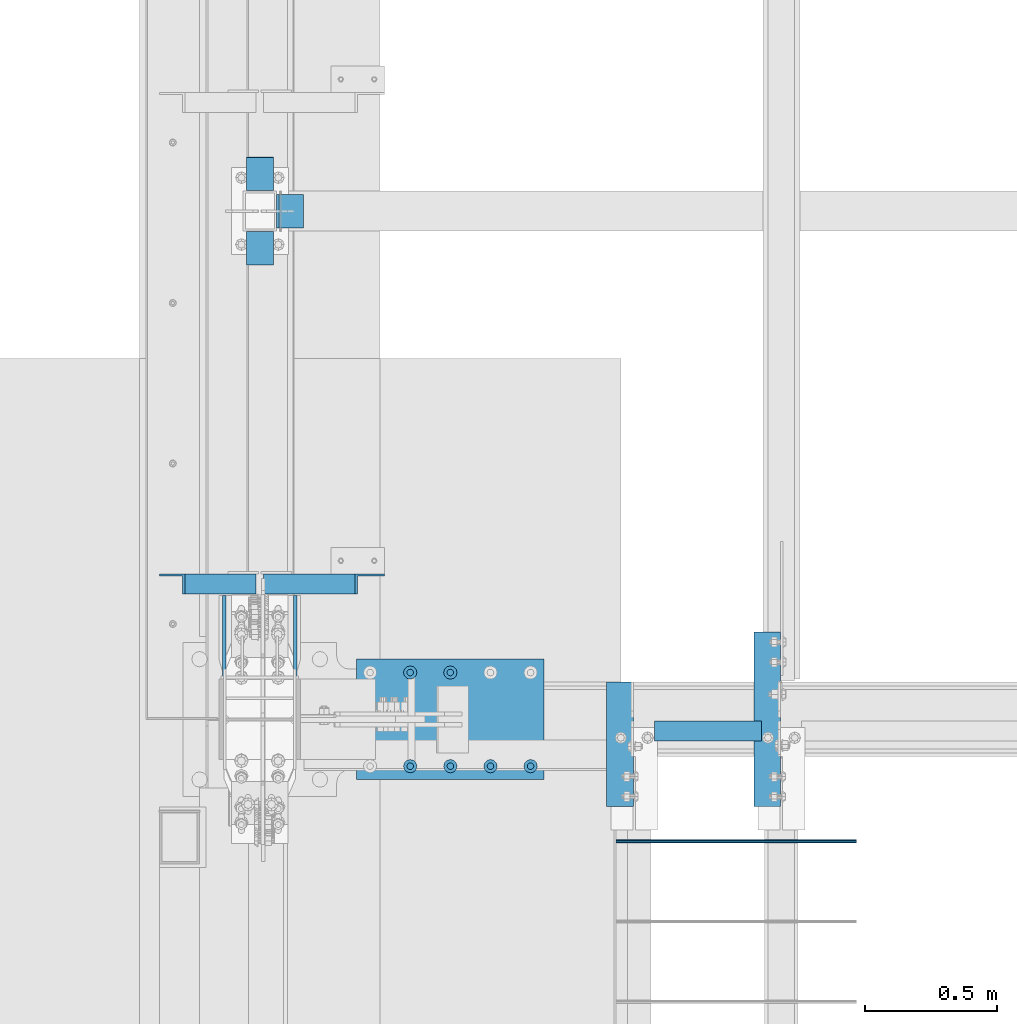
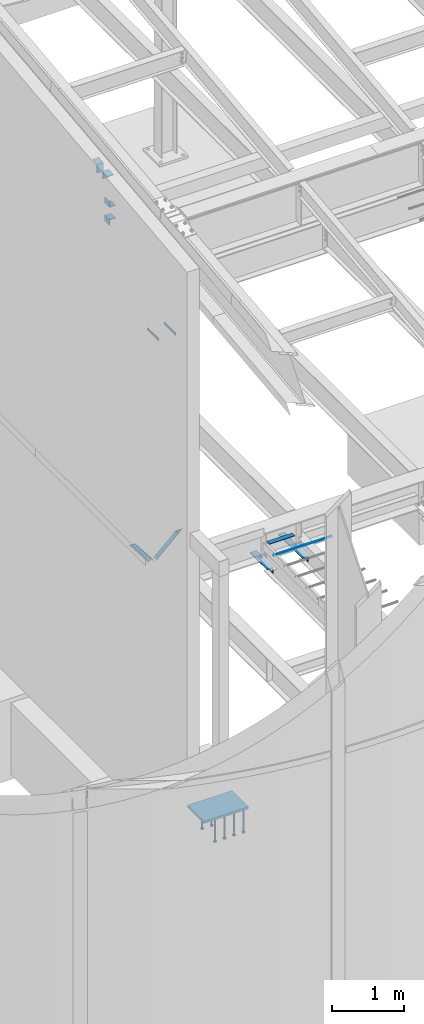
# One storey, part 806 of 1179: 17 beams, 2 members, 8 elements without a shape of their own.
"""IFC2X3 building model written with IfcOpenShell, lengths in millimetres."""

from ifc_helpers import new_model, si_unit, frame, origin_with_axes, place, context, subcontext, project, spatial, faceted_brep, material, type_object, element, aggregate, save


model = new_model("IFC2X3")

# Units and contexts
model_context = context("Model", 3, precision=1e-05, world=origin_with_axes())
body_context = subcontext(model_context, "Body", "Model", "MODEL_VIEW")
ifc_project = project(units=[si_unit("LENGTHUNIT", "METRE", prefix="MILLI"), si_unit("AREAUNIT", "SQUARE_METRE"), si_unit("VOLUMEUNIT", "CUBIC_METRE"), si_unit("MASSUNIT", "GRAM", prefix="KILO"), si_unit("TIMEUNIT", "SECOND"), si_unit("PLANEANGLEUNIT", "RADIAN"), si_unit("SOLIDANGLEUNIT", "STERADIAN"), si_unit("THERMODYNAMICTEMPERATUREUNIT", "DEGREE_CELSIUS"), si_unit("LUMINOUSINTENSITYUNIT", "LUMEN")], contexts=[model_context])

# Site, building, storey
site_placement = place(None, origin_with_axes())
site = spatial("IfcSite", under=ifc_project, at=site_placement, CompositionType="ELEMENT")
building_placement = place(site_placement, origin_with_axes())
building = spatial("IfcBuilding", under=site, at=building_placement, Name="Undefined", CompositionType="ELEMENT")
storey_placement = place(building_placement, origin_with_axes())
storey = spatial("IfcBuildingStorey", under=building, at=storey_placement, Name="Undefined", CompositionType="ELEMENT", Elevation=0.0)

# Assembly, beams
assembly_1_placement = place(storey_placement, origin_with_axes())
assembly_1 = element("IfcElementAssembly", 1, at=assembly_1_placement, inside=storey, Name="BEAM", AssemblyPlace="NOTDEFINED", PredefinedType="RIGID_FRAME")
ifc_material_1 = material(Name="STEEL/A36")
beam_type_1 = type_object("IfcBeamType", PredefinedType="NOTDEFINED")
beam_1_placement = place(assembly_1_placement, frame((432.347216092612, 7448.53595929762, 9390.66783296223), z_axis=(-1.0, 0.0, 0.0), x_axis=(0.0, 0.0, 1.0)))
beam_1 = element("IfcBeam", 2, at=beam_1_placement, type_object=beam_type_1, material=ifc_material_1, Name="BENT_PLATE", context=body_context, shape_type="Brep", body=[
    faceted_brep([(0.0, -4.76249999999982, -50.7999999999993), (0.0, -4.76249999999982, 50.7999999999993), (0.0, 4.76249999999982, 50.7999999999993), (0.0, 4.76249999999982, -50.7999999999993), (136.064419113565, 4.76249999999982, 50.8), (136.064419113565, 4.76249999999982, -50.8), (144.578182144351, -4.76249999999982, -50.8), (144.578182144351, -4.76249999999982, 50.8), (149.307267391649, 122.50635470422, 50.8), (149.307267391649, 122.50635470422, -50.8), (158.772587961741, 121.441774267915, 50.8), (158.772587961741, 121.441774267915, -50.8)], [[[0, 1, 2, 3]], [[3, 2, 4, 5]], [[1, 0, 6, 7]], [[5, 4, 8, 9]], [[4, 2, 1, 7, 10, 8]], [[7, 6, 11, 10]], [[6, 0, 3, 5, 9, 11]], [[10, 11, 9, 8]]]),
])
beam_2_placement = place(assembly_1_placement, frame((432.347216092612, 7162.55025962123, 9498.67298678495), z_axis=(1.0, 0.0, 0.0), x_axis=(0.0, 0.993674063495503, 0.11230251794299)))
beam_2 = element("IfcBeam", 3, at=beam_2_placement, type_object=beam_type_1, material=ifc_material_1, Name="BENT_PLATE", context=body_context, shape_type="Brep", body=[
    faceted_brep([(0.0, -4.76249999999982, -50.7999999999993), (0.0, -4.76249999999982, 50.7999999999993), (0.0, 4.76249999999982, 50.7999999999993), (0.0, 4.76249999999982, -50.7999999999993), (127.000478078538, 4.7624999806776, 50.8), (127.000478078538, 4.7624999806776, -50.8), (116.338348641526, -4.76250001769222, -50.8), (116.338348641526, -4.76250001769222, 50.8), (112.7380583003, -121.434106082392, 50.8), (112.7380583003, -121.434106082392, -50.8), (103.273312845498, -120.364424599007, 50.8), (103.273312845498, -120.364424599007, -50.8)], [[[0, 1, 2, 3]], [[3, 2, 4, 5]], [[1, 0, 6, 7]], [[5, 4, 8, 9]], [[4, 2, 1, 7, 10, 8]], [[7, 6, 11, 10]], [[6, 0, 3, 5, 9, 11]], [[10, 11, 9, 8]]]),
])
aggregate(assembly_1, [beam_1, beam_2])

# Assembly, member
assembly_2_placement = place(storey_placement, origin_with_axes())
assembly_2 = element("IfcElementAssembly", 4, at=assembly_2_placement, inside=storey, Name="ANGLE", AssemblyPlace="NOTDEFINED", PredefinedType="RIGID_FRAME")
member_type = type_object("IfcMemberType", Name="L3X3X1/4", PredefinedType="NOTDEFINED")
member_1_placement = place(assembly_2_placement, frame((472.414639168561, 5949.15999128227, 3736.19330123132), z_axis=(0.0, -1.0, 0.0), x_axis=(0.729484494811633, 0.0, 0.683997347823379)))
member_1 = element("IfcMember", 5, at=member_1_placement, type_object=member_type, material=ifc_material_1, Name="ANGLE", ObjectType="L3X3X1/4", context=body_context, shape_type="Brep", body=[
    faceted_brep([(0.0, 38.0999999999985, -38.0999999999999), (0.0, 38.0999999999985, 38.0999999999999), (475.752341075195, 38.0999999999181, 38.1000000000004), (475.752341075195, 38.0999999999181, -38.1000000000004), (0.0, 31.75, 38.1000000000004), (482.524628360803, 31.7499999999177, 38.1000000000004), (0.0, 31.75, -31.75), (482.524628360803, 31.7499999999177, -31.75), (0.0, -38.0999999999985, -31.75), (557.019788502486, -38.1000000000854, -31.75), (0.0, -38.0999999999985, -38.0999999999999), (557.019788502486, -38.1000000000854, -38.1000000000004)], [[[0, 1, 2, 3]], [[1, 4, 5, 2]], [[4, 6, 7, 5]], [[6, 8, 9, 7]], [[8, 10, 11, 9]], [[10, 0, 3, 11]], [[5, 7, 9, 11, 3, 2]], [[10, 8, 6, 4, 1, 0]]]),
])
aggregate(assembly_2, [member_1])

assembly_3_placement = place(storey_placement, origin_with_axes())
assembly_3 = element("IfcElementAssembly", 6, at=assembly_3_placement, inside=storey, Name="ANGLE", AssemblyPlace="NOTDEFINED", PredefinedType="RIGID_FRAME")
member_2_placement = place(assembly_3_placement, frame((80.8196258456446, 5949.15999128227, 4125.56128839178), z_axis=(0.0, -1.0, 0.0), x_axis=(0.614083067285056, 0.0, -0.789241399366364)))
member_2 = element("IfcMember", 7, at=member_2_placement, type_object=member_type, material=ifc_material_1, Name="ANGLE", ObjectType="L3X3X1/4", context=body_context, shape_type="Brep", body=[
    faceted_brep([(59.3707492954454, 38.0999999999781, -38.1000000000004), (59.3707492954454, 38.0999999999781, 38.1000000000004), (499.083854779058, 38.0999999998585, 38.1000000000004), (499.083854779058, 38.0999999998585, -38.1000000000004), (54.4300207928691, 31.7499999999804, 38.1000000000004), (499.083854779056, 31.7499999998595, 38.1000000000004), (54.4300207928691, 31.7499999999804, -31.75), (499.083854779056, 31.7499999998595, -31.75), (0.0820072645328764, -38.0999999999945, -31.75), (499.083854779043, -38.10000000013, -31.75), (0.0820072645328764, -38.0999999999945, -38.1000000000004), (499.083854779043, -38.10000000013, -38.1000000000004)], [[[0, 1, 2, 3]], [[1, 4, 5, 2]], [[4, 6, 7, 5]], [[6, 8, 9, 7]], [[8, 10, 11, 9]], [[10, 0, 3, 11]], [[5, 7, 9, 11, 3, 2]], [[10, 8, 6, 4, 1, 0]]]),
])
aggregate(assembly_3, [member_2])

# Assembly, beams
assembly_4_placement = place(storey_placement, origin_with_axes())
assembly_4 = element("IfcElementAssembly", 8, at=assembly_4_placement, inside=storey, Name="BEAM", AssemblyPlace="NOTDEFINED", PredefinedType="RIGID_FRAME")
beam_type_2 = type_object("IfcBeamType", Name="L4X4X1/2", PredefinedType="NOTDEFINED")
beam_3_placement = place(assembly_4_placement, frame((1800.22499984953, 5104.60611419343, 3584.575), z_axis=(0.0, 0.0, -1.0), x_axis=(0.0, 1.0, 0.0)))
beam_3 = element("IfcBeam", 9, at=beam_3_placement, type_object=beam_type_2, material=ifc_material_1, Name="ANGLE", ObjectType="L4X4X1/2", context=body_context, shape_type="Brep", body=[
    faceted_brep([(1.90993887372315e-11, 50.8000000000002, -50.8000000000002), (1.90993887372315e-11, 50.8000000000002, 50.8000000000002), (472.281387536708, 50.8000000000452, 50.8000000000002), (472.281387536708, 50.8000000000452, -50.8000000000002), (1.45519152283669e-11, 38.1000000000004, 50.8000000000002), (472.281387536704, 38.1000000000454, 50.8000000000002), (0.0, 38.0999999999985, -38.0999999999999), (472.281387536704, 38.1000000000454, -38.0999999999999), (-1.81898940354586e-11, -50.7999999999997, -38.0999999999999), (472.281387536672, -50.7999999999547, -38.0999999999999), (-1.81898940354586e-11, -50.7999999999997, -50.8000000000002), (472.281387536672, -50.7999999999547, -50.8000000000002)], [[[0, 1, 2, 3]], [[1, 4, 5, 2]], [[4, 6, 7, 5]], [[6, 8, 9, 7]], [[8, 10, 11, 9]], [[10, 0, 3, 11]], [[5, 7, 9, 11, 3, 2]], [[10, 8, 6, 4, 1, 0]]]),
])
beam_4_placement = place(assembly_4_placement, frame((2359.025, 5103.81250305176, 3584.575), z_axis=(0.0, 0.0, -1.0), x_axis=(0.0, 1.0, 0.0)))
beam_4 = element("IfcBeam", 10, at=beam_4_placement, type_object=beam_type_2, material=ifc_material_1, Name="ANGLE", ObjectType="L4X4X1/2", context=body_context, shape_type="Brep", body=[
    faceted_brep([(1.90993887372315e-11, 50.8000000000002, -50.8000000000002), (1.90993887372315e-11, 50.8000000000002, 50.8000000000002), (663.574996948242, 50.8000000000002, 50.8000000000002), (663.574996948242, 50.8000000000002, -50.8000000000002), (1.45519152283669e-11, 38.1000000000004, 50.8000000000002), (663.574996948242, 38.1000000000004, 50.8000000000002), (0.0, 38.0999999999985, -38.0999999999999), (663.574996948242, 38.1000000000004, -38.0999999999999), (-1.81898940354586e-11, -50.7999999999997, -38.0999999999999), (663.574996948242, -50.8000000000002, -38.0999999999999), (-1.81898940354586e-11, -50.7999999999997, -50.8000000000002), (663.574996948242, -50.8000000000002, -50.8000000000002)], [[[0, 1, 2, 3]], [[1, 4, 5, 2]], [[4, 6, 7, 5]], [[6, 8, 9, 7]], [[8, 10, 11, 9]], [[10, 0, 3, 11]], [[5, 7, 9, 11, 3, 2]], [[10, 8, 6, 4, 1, 0]]]),
])

assembly_5_placement = place(storey_placement, origin_with_axes())
assembly_5 = element("IfcElementAssembly", 11, at=assembly_5_placement, inside=storey, Name="COLUMN", AssemblyPlace="NOTDEFINED", PredefinedType="RIGID_FRAME")
beam_type_3 = type_object("IfcBeamType", Name="L4X4X3/8", PredefinedType="NOTDEFINED")
beam_5_placement = place(assembly_5_placement, frame((546.644791494267, 7302.5, 8597.9), z_axis=(1.0, 0.0, 0.0), x_axis=(0.0, 1.0, 0.0)))
beam_5 = element("IfcBeam", 12, at=beam_5_placement, type_object=beam_type_3, material=ifc_material_1, Name="ANGLE", ObjectType="L4X4X3/8", context=body_context, shape_type="Brep", body=[
    faceted_brep([(1.90993887372315e-11, 50.8000000000002, -50.8000000000002), (1.90993887372315e-11, 50.8000000000002, 50.8000000000002), (126.999999999993, 50.8000000000002, 50.7999999999993), (126.999999999993, 50.8000000000002, -50.7999999999993), (0.0, 41.2750000000015, 50.8000000000029), (126.999999999993, 41.2749999999996, 50.7999999999993), (0.0, 41.2750000000015, -41.2750000000015), (126.999999999993, 41.2749999999996, -41.2749999999996), (0.0, -50.7999999999993, -41.2750000000015), (126.999999999993, -50.8000000000002, -41.2749999999996), (-1.81898940354586e-11, -50.7999999999997, -50.8000000000002), (126.999999999993, -50.8000000000002, -50.7999999999993)], [[[0, 1, 2, 3]], [[1, 4, 5, 2]], [[4, 6, 7, 5]], [[6, 8, 9, 7]], [[8, 10, 11, 9]], [[10, 0, 3, 11]], [[5, 7, 9, 11, 3, 2]], [[10, 8, 6, 4, 1, 0]]]),
])
beam_6_placement = place(assembly_5_placement, frame((546.644791494267, 7302.5, 8904.2875), z_axis=(0.0, 0.0, 1.0), x_axis=(0.0, 1.0, 0.0)))
beam_6 = element("IfcBeam", 13, at=beam_6_placement, type_object=beam_type_3, material=ifc_material_1, Name="ANGLE", ObjectType="L4X4X3/8", context=body_context, shape_type="Brep", body=[
    faceted_brep([(1.90993887372315e-11, 50.8000000000002, -50.8000000000002), (1.90993887372315e-11, 50.8000000000002, 50.8000000000002), (126.999999999993, 50.8000000000002, 50.7999999999993), (126.999999999993, 50.8000000000002, -50.7999999999993), (0.0, 41.2750000000015, 50.8000000000029), (126.999999999993, 41.2749999999996, 50.7999999999993), (0.0, 41.2750000000015, -41.2750000000015), (126.999999999993, 41.2749999999996, -41.2749999999996), (0.0, -50.7999999999993, -41.2750000000015), (126.999999999993, -50.8000000000002, -41.2749999999996), (-1.81898940354586e-11, -50.7999999999997, -50.8000000000002), (126.999999999993, -50.8000000000002, -50.7999999999993)], [[[0, 1, 2, 3]], [[1, 4, 5, 2]], [[4, 6, 7, 5]], [[6, 8, 9, 7]], [[8, 10, 11, 9]], [[10, 0, 3, 11]], [[5, 7, 9, 11, 3, 2]], [[10, 8, 6, 4, 1, 0]]]),
])
aggregate(assembly_5, [beam_5, beam_6])

assembly_6_placement = place(storey_placement, origin_with_axes())
assembly_6 = element("IfcElementAssembly", 14, at=assembly_6_placement, inside=storey, Name="COLUMN", AssemblyPlace="NOTDEFINED", PredefinedType="RIGID_FRAME")
beam_type_4 = type_object("IfcBeamType", PredefinedType="NOTDEFINED")
beam_7_placement = place(assembly_6_placement, frame((296.862500000007, 5905.49999998408, 7727.95000000912), z_axis=(0.0, 0.0, 1.0), x_axis=(0.0, -1.0, 0.0)))
beam_7 = element("IfcBeam", 15, at=beam_7_placement, type_object=beam_type_4, material=ifc_material_1, Name="PLATE", context=body_context, shape_type="Brep", body=[
    faceted_brep([(0.0, 6.34999999999854, -19.0499999999993), (0.0, 6.35000000000036, 19.0499999999993), (317.5, 6.34999999999854, 19.0499999999993), (317.5, 6.34999999999854, -19.0499999999993), (0.0, -6.35000000000036, 19.0499999999993), (317.5, -6.34999999999854, 19.0499999999993), (0.0, -6.34999999999854, -19.0499999999993), (317.5, -6.34999999999854, -19.0499999999993)], [[[0, 1, 2, 3]], [[1, 4, 5, 2]], [[4, 6, 7, 5]], [[6, 0, 3, 7]], [[5, 7, 3, 2]], [[6, 4, 1, 0]]]),
])
beam_8_placement = place(assembly_6_placement, frame((566.737500000005, 5905.4999999923, 7727.95000000912), z_axis=(0.0, 0.0, 1.0), x_axis=(0.0, -1.0, 0.0)))
beam_8 = element("IfcBeam", 16, at=beam_8_placement, type_object=beam_type_4, material=ifc_material_1, Name="PLATE", context=body_context, shape_type="Brep", body=[
    faceted_brep([(0.0, 6.34999999999854, -19.0499999999993), (0.0, 6.35000000000036, 19.0499999999993), (317.5, 6.34999999999854, 19.0499999999993), (317.5, 6.34999999999854, -19.0499999999993), (0.0, -6.35000000000036, 19.0499999999993), (317.5, -6.34999999999854, 19.0499999999993), (0.0, -6.34999999999854, -19.0499999999993), (317.5, -6.34999999999854, -19.0499999999993)], [[[0, 1, 2, 3]], [[1, 4, 5, 2]], [[4, 6, 7, 5]], [[6, 0, 3, 7]], [[5, 7, 3, 2]], [[6, 4, 1, 0]]]),
])
aggregate(assembly_6, [beam_7, beam_8])

# Beam
beam_type_5 = type_object("IfcBeamType", PredefinedType="NOTDEFINED")
beam_9_placement = place(assembly_4_placement, frame((1930.4, 5391.15, 3844.131), z_axis=(0.0, 1.0, 0.0), x_axis=(1.0, 0.0, 0.0)))
beam_9 = element("IfcBeam", 17, at=beam_9_placement, type_object=beam_type_5, material=ifc_material_1, Name="PLATE", context=body_context, shape_type="Brep", body=[
    faceted_brep([(0.0, 3.96900000000005, -38.1000000000004), (0.0, 3.96900000000005, 38.1000000000004), (406.4, 3.96900000000005, 38.1000000000004), (406.4, 3.96900000000005, -38.1000000000004), (-3.63797880709171e-12, -3.96900000000005, 38.1000000000004), (406.4, -3.96900000000005, 38.1000000000004), (-3.63797880709171e-12, -3.96900000000005, -38.1000000000004), (406.4, -3.96900000000005, -38.1000000000004)], [[[0, 1, 2, 3]], [[1, 4, 5, 2]], [[4, 6, 7, 5]], [[6, 0, 3, 7]], [[5, 7, 3, 2]], [[6, 4, 1, 0]]]),
])

aggregate(assembly_4, [beam_3, beam_4, beam_9])

# Assembly, beam
assembly_7_placement = place(storey_placement, origin_with_axes())
assembly_7 = element("IfcElementAssembly", 18, at=assembly_7_placement, inside=storey, Name="#4 DOWEL", AssemblyPlace="NOTDEFINED", PredefinedType="NOTDEFINED")
ifc_material_2 = material(Name="REBAR/A615-40")
beam_type_6 = type_object("IfcBeamType", Name="#4 DOWEL", PredefinedType="NOTDEFINED")
beam_10_placement = place(assembly_7_placement, frame((1784.35000076294, 4972.94259468122, 3943.35000610352), z_axis=(0.0, 1.0, 0.0), x_axis=(1.0, 0.0, 0.0)))
beam_10 = element("IfcBeam", 19, at=beam_10_placement, type_object=beam_type_6, material=ifc_material_2, Name="#4 DOWEL", ObjectType="#4 DOWEL", context=body_context, shape_type="Brep", body=[
    faceted_brep([(0.0, -6.34999999999854, 0.0), (0.0, -4.49012806053361, -4.49012806053452), (914.399999999994, -4.49012806053452, -4.49012806042992), (914.399999999994, -6.34999999999991, 1.0550138540566e-10), (0.0, 0.0, -6.34999999999991), (914.399999999994, 0.0, -6.34999999989668), (0.0, 4.49012806053361, -4.49012806053452), (914.399999999994, 4.49012806053452, -4.49012806042992), (0.0, 6.34999999999854, 0.0), (914.399999999994, 6.34999999999991, 1.0550138540566e-10), (0.0, 4.49012806053361, 4.49012806053452), (914.399999999995, 4.49012806053452, 4.49012806064184), (0.0, 0.0, 6.34999999999991), (914.399999999995, 0.0, 6.35000000010768), (0.0, -4.49012806053361, 4.49012806053452), (914.399999999995, -4.49012806053452, 4.49012806064184)], [[[0, 1, 2, 3]], [[1, 4, 5, 2]], [[4, 6, 7, 5]], [[6, 8, 9, 7]], [[8, 10, 11, 9]], [[10, 12, 13, 11]], [[12, 14, 15, 13]], [[14, 0, 3, 15]], [[5, 7, 9, 11, 13, 15, 3, 2]], [[14, 12, 10, 8, 6, 4, 1, 0]]]),
])
aggregate(assembly_7, [beam_10])

# Assembly, beams
assembly_8_placement = place(storey_placement, origin_with_axes())
assembly_8 = element("IfcElementAssembly", 20, at=assembly_8_placement, inside=storey, Name="EMBED_PLATE", AssemblyPlace="NOTDEFINED", PredefinedType="RIGID_FRAME")
ifc_material_3 = material(Name="STEEL/A108")
beam_type_7 = type_object("IfcBeamType", Name="STUD_1-DIA", PredefinedType="NOTDEFINED")
beam_11_placement = place(assembly_8_placement, frame((1155.7, 5613.4, -393.700000000007), z_axis=(1.0, 0.0, 0.0), x_axis=(0.0, 0.0, -1.0)))
beam_11 = element("IfcBeam", 21, at=beam_11_placement, type_object=beam_type_7, material=ifc_material_3, Name="STUD", ObjectType="STUD_1-DIA", context=body_context, shape_type="Brep", body=[
    faceted_brep([(0.0, -12.7, 0.0), (0.0, -11.0, -6.34999990463257), (382.016, -11.0, -6.34999990463257), (382.016, -12.6999998092651, 0.0), (0.0, -6.34999990463257, -11.0), (382.016, -6.34999990463257, -11.0), (0.0, 0.0, -12.6999998092651), (382.016, 0.0, -12.6999998092651), (0.0, 6.34999990463257, -11.0), (382.016, 6.34999990463257, -11.0), (0.0, 11.0, -6.34999990463257), (382.016, 11.0, -6.34999990463257), (0.0, 12.7, 0.0), (382.016, 12.6999998092651, 0.0), (0.0, 11.0, 6.34999990463257), (382.016, 11.0, 6.34999990463257), (0.0, 6.34999990463257, 11.0), (382.016, 6.34999990463257, 11.0), (0.0, 0.0, 12.6999998092651), (382.016, 0.0, 12.6999998092651), (0.0, -6.34999990463257, 11.0), (382.016, -6.34999990463257, 11.0), (0.0, -11.0, 6.34999990463257), (382.016, -11.0, 6.34999990463257), (386.08, -22.0, -12.6999998092651), (386.08, -25.3999996185303, 0.0), (386.08, -12.6999998092651, -22.0), (386.08, 0.0, -25.3999996185303), (386.08, 12.6999998092651, -22.0), (386.08, 22.0, -12.6999998092651), (386.08, 25.3999996185303, 0.0), (386.08, 22.0, 12.6999998092651), (386.08, 12.6999998092651, 22.0), (386.08, 0.0, 25.3999996185303), (386.08, -12.6999998092651, 22.0), (386.08, -22.0, 12.6999998092651), (406.4, -22.0, -12.6999998092651), (406.4, -25.3999996185303, 0.0), (406.4, -12.6999998092651, -22.0), (406.4, 0.0, -25.3999996185303), (406.4, 12.6999998092651, -22.0), (406.4, 22.0, -12.6999998092651), (406.4, 25.3999996185303, 0.0), (406.4, 22.0, 12.6999998092651), (406.4, 12.6999998092651, 22.0), (406.4, 0.0, 25.3999996185303), (406.4, -12.6999998092651, 22.0), (406.4, -22.0, 12.6999998092651)], [[[0, 1, 2, 3]], [[1, 4, 5, 2]], [[4, 6, 7, 5]], [[6, 8, 9, 7]], [[8, 10, 11, 9]], [[10, 12, 13, 11]], [[12, 14, 15, 13]], [[14, 16, 17, 15]], [[16, 18, 19, 17]], [[18, 20, 21, 19]], [[20, 22, 23, 21]], [[22, 0, 3, 23]], [[22, 20, 18, 16, 14, 12, 10, 8, 6, 4, 1, 0]], [[3, 2, 24, 25]], [[2, 5, 26, 24]], [[5, 7, 27, 26]], [[7, 9, 28, 27]], [[9, 11, 29, 28]], [[11, 13, 30, 29]], [[13, 15, 31, 30]], [[15, 17, 32, 31]], [[17, 19, 33, 32]], [[19, 21, 34, 33]], [[21, 23, 35, 34]], [[23, 3, 25, 35]], [[25, 24, 36, 37]], [[24, 26, 38, 36]], [[26, 27, 39, 38]], [[27, 28, 40, 39]], [[28, 29, 41, 40]], [[29, 30, 42, 41]], [[30, 31, 43, 42]], [[31, 32, 44, 43]], [[32, 33, 45, 44]], [[33, 34, 46, 45]], [[34, 35, 47, 46]], [[35, 25, 37, 47]], [[38, 39, 40, 41, 42, 43, 44, 45, 46, 47, 37, 36]]]),
])
beam_12_placement = place(assembly_8_placement, frame((1003.3, 5613.4, -393.700000000007), z_axis=(1.0, 0.0, 0.0), x_axis=(0.0, 0.0, -1.0)))
beam_12 = element("IfcBeam", 22, at=beam_12_placement, type_object=beam_type_7, material=ifc_material_3, Name="STUD", ObjectType="STUD_1-DIA", context=body_context, shape_type="Brep", body=[
    faceted_brep([(0.0, -12.7, 0.0), (0.0, -11.0, -6.34999990463257), (382.016, -11.0, -6.34999990463257), (382.016, -12.6999998092651, 0.0), (0.0, -6.34999990463257, -11.0), (382.016, -6.34999990463257, -11.0), (0.0, 0.0, -12.6999998092651), (382.016, 0.0, -12.6999998092651), (0.0, 6.34999990463257, -11.0), (382.016, 6.34999990463257, -11.0), (0.0, 11.0, -6.34999990463257), (382.016, 11.0, -6.34999990463257), (0.0, 12.7, 0.0), (382.016, 12.6999998092651, 0.0), (0.0, 11.0, 6.34999990463257), (382.016, 11.0, 6.34999990463257), (0.0, 6.34999990463257, 11.0), (382.016, 6.34999990463257, 11.0), (0.0, 0.0, 12.6999998092651), (382.016, 0.0, 12.6999998092651), (0.0, -6.34999990463257, 11.0), (382.016, -6.34999990463257, 11.0), (0.0, -11.0, 6.34999990463257), (382.016, -11.0, 6.34999990463257), (386.08, -22.0, -12.6999998092651), (386.08, -25.3999996185303, 0.0), (386.08, -12.6999998092651, -22.0), (386.08, 0.0, -25.3999996185303), (386.08, 12.6999998092651, -22.0), (386.08, 22.0, -12.6999998092651), (386.08, 25.3999996185303, 0.0), (386.08, 22.0, 12.6999998092651), (386.08, 12.6999998092651, 22.0), (386.08, 0.0, 25.3999996185303), (386.08, -12.6999998092651, 22.0), (386.08, -22.0, 12.6999998092651), (406.4, -22.0, -12.6999998092651), (406.4, -25.3999996185303, 0.0), (406.4, -12.6999998092651, -22.0), (406.4, 0.0, -25.3999996185303), (406.4, 12.6999998092651, -22.0), (406.4, 22.0, -12.6999998092651), (406.4, 25.3999996185303, 0.0), (406.4, 22.0, 12.6999998092651), (406.4, 12.6999998092651, 22.0), (406.4, 0.0, 25.3999996185303), (406.4, -12.6999998092651, 22.0), (406.4, -22.0, 12.6999998092651)], [[[0, 1, 2, 3]], [[1, 4, 5, 2]], [[4, 6, 7, 5]], [[6, 8, 9, 7]], [[8, 10, 11, 9]], [[10, 12, 13, 11]], [[12, 14, 15, 13]], [[14, 16, 17, 15]], [[16, 18, 19, 17]], [[18, 20, 21, 19]], [[20, 22, 23, 21]], [[22, 0, 3, 23]], [[22, 20, 18, 16, 14, 12, 10, 8, 6, 4, 1, 0]], [[3, 2, 24, 25]], [[2, 5, 26, 24]], [[5, 7, 27, 26]], [[7, 9, 28, 27]], [[9, 11, 29, 28]], [[11, 13, 30, 29]], [[13, 15, 31, 30]], [[15, 17, 32, 31]], [[17, 19, 33, 32]], [[19, 21, 34, 33]], [[21, 23, 35, 34]], [[23, 3, 25, 35]], [[25, 24, 36, 37]], [[24, 26, 38, 36]], [[26, 27, 39, 38]], [[27, 28, 40, 39]], [[28, 29, 41, 40]], [[29, 30, 42, 41]], [[30, 31, 43, 42]], [[31, 32, 44, 43]], [[32, 33, 45, 44]], [[33, 34, 46, 45]], [[34, 35, 47, 46]], [[35, 25, 37, 47]], [[38, 39, 40, 41, 42, 43, 44, 45, 46, 47, 37, 36]]]),
])
beam_13_placement = place(assembly_8_placement, frame((1460.5, 5257.8, -393.700000000007), z_axis=(1.0, 0.0, 0.0), x_axis=(0.0, 0.0, -1.0)))
beam_13 = element("IfcBeam", 23, at=beam_13_placement, type_object=beam_type_7, material=ifc_material_3, Name="STUD", ObjectType="STUD_1-DIA", context=body_context, shape_type="Brep", body=[
    faceted_brep([(0.0, -12.7, 0.0), (0.0, -11.0, -6.34999990463257), (382.016, -11.0, -6.34999990463257), (382.016, -12.6999998092651, 0.0), (0.0, -6.34999990463257, -11.0), (382.016, -6.34999990463257, -11.0), (0.0, 0.0, -12.6999998092651), (382.016, 0.0, -12.6999998092651), (0.0, 6.34999990463257, -11.0), (382.016, 6.34999990463257, -11.0), (0.0, 11.0, -6.34999990463257), (382.016, 11.0, -6.34999990463257), (0.0, 12.7, 0.0), (382.016, 12.6999998092651, 0.0), (0.0, 11.0, 6.34999990463257), (382.016, 11.0, 6.34999990463257), (0.0, 6.34999990463257, 11.0), (382.016, 6.34999990463257, 11.0), (0.0, 0.0, 12.6999998092651), (382.016, 0.0, 12.6999998092651), (0.0, -6.34999990463257, 11.0), (382.016, -6.34999990463257, 11.0), (0.0, -11.0, 6.34999990463257), (382.016, -11.0, 6.34999990463257), (386.08, -22.0, -12.6999998092651), (386.08, -25.3999996185303, 0.0), (386.08, -12.6999998092651, -22.0), (386.08, 0.0, -25.3999996185303), (386.08, 12.6999998092651, -22.0), (386.08, 22.0, -12.6999998092651), (386.08, 25.3999996185303, 0.0), (386.08, 22.0, 12.6999998092651), (386.08, 12.6999998092651, 22.0), (386.08, 0.0, 25.3999996185303), (386.08, -12.6999998092651, 22.0), (386.08, -22.0, 12.6999998092651), (406.4, -22.0, -12.6999998092651), (406.4, -25.3999996185303, 0.0), (406.4, -12.6999998092651, -22.0), (406.4, 0.0, -25.3999996185303), (406.4, 12.6999998092651, -22.0), (406.4, 22.0, -12.6999998092651), (406.4, 25.3999996185303, 0.0), (406.4, 22.0, 12.6999998092651), (406.4, 12.6999998092651, 22.0), (406.4, 0.0, 25.3999996185303), (406.4, -12.6999998092651, 22.0), (406.4, -22.0, 12.6999998092651)], [[[0, 1, 2, 3]], [[1, 4, 5, 2]], [[4, 6, 7, 5]], [[6, 8, 9, 7]], [[8, 10, 11, 9]], [[10, 12, 13, 11]], [[12, 14, 15, 13]], [[14, 16, 17, 15]], [[16, 18, 19, 17]], [[18, 20, 21, 19]], [[20, 22, 23, 21]], [[22, 0, 3, 23]], [[22, 20, 18, 16, 14, 12, 10, 8, 6, 4, 1, 0]], [[3, 2, 24, 25]], [[2, 5, 26, 24]], [[5, 7, 27, 26]], [[7, 9, 28, 27]], [[9, 11, 29, 28]], [[11, 13, 30, 29]], [[13, 15, 31, 30]], [[15, 17, 32, 31]], [[17, 19, 33, 32]], [[19, 21, 34, 33]], [[21, 23, 35, 34]], [[23, 3, 25, 35]], [[25, 24, 36, 37]], [[24, 26, 38, 36]], [[26, 27, 39, 38]], [[27, 28, 40, 39]], [[28, 29, 41, 40]], [[29, 30, 42, 41]], [[30, 31, 43, 42]], [[31, 32, 44, 43]], [[32, 33, 45, 44]], [[33, 34, 46, 45]], [[34, 35, 47, 46]], [[35, 25, 37, 47]], [[38, 39, 40, 41, 42, 43, 44, 45, 46, 47, 37, 36]]]),
])
beam_14_placement = place(assembly_8_placement, frame((1308.1, 5257.8, -393.700000000007), z_axis=(1.0, 0.0, 0.0), x_axis=(0.0, 0.0, -1.0)))
beam_14 = element("IfcBeam", 24, at=beam_14_placement, type_object=beam_type_7, material=ifc_material_3, Name="STUD", ObjectType="STUD_1-DIA", context=body_context, shape_type="Brep", body=[
    faceted_brep([(0.0, -12.7, 0.0), (0.0, -11.0, -6.34999990463257), (382.016, -11.0, -6.34999990463257), (382.016, -12.6999998092651, 0.0), (0.0, -6.34999990463257, -11.0), (382.016, -6.34999990463257, -11.0), (0.0, 0.0, -12.6999998092651), (382.016, 0.0, -12.6999998092651), (0.0, 6.34999990463257, -11.0), (382.016, 6.34999990463257, -11.0), (0.0, 11.0, -6.34999990463257), (382.016, 11.0, -6.34999990463257), (0.0, 12.7, 0.0), (382.016, 12.6999998092651, 0.0), (0.0, 11.0, 6.34999990463257), (382.016, 11.0, 6.34999990463257), (0.0, 6.34999990463257, 11.0), (382.016, 6.34999990463257, 11.0), (0.0, 0.0, 12.6999998092651), (382.016, 0.0, 12.6999998092651), (0.0, -6.34999990463257, 11.0), (382.016, -6.34999990463257, 11.0), (0.0, -11.0, 6.34999990463257), (382.016, -11.0, 6.34999990463257), (386.08, -22.0, -12.6999998092651), (386.08, -25.3999996185303, 0.0), (386.08, -12.6999998092651, -22.0), (386.08, 0.0, -25.3999996185303), (386.08, 12.6999998092651, -22.0), (386.08, 22.0, -12.6999998092651), (386.08, 25.3999996185303, 0.0), (386.08, 22.0, 12.6999998092651), (386.08, 12.6999998092651, 22.0), (386.08, 0.0, 25.3999996185303), (386.08, -12.6999998092651, 22.0), (386.08, -22.0, 12.6999998092651), (406.4, -22.0, -12.6999998092651), (406.4, -25.3999996185303, 0.0), (406.4, -12.6999998092651, -22.0), (406.4, 0.0, -25.3999996185303), (406.4, 12.6999998092651, -22.0), (406.4, 22.0, -12.6999998092651), (406.4, 25.3999996185303, 0.0), (406.4, 22.0, 12.6999998092651), (406.4, 12.6999998092651, 22.0), (406.4, 0.0, 25.3999996185303), (406.4, -12.6999998092651, 22.0), (406.4, -22.0, 12.6999998092651)], [[[0, 1, 2, 3]], [[1, 4, 5, 2]], [[4, 6, 7, 5]], [[6, 8, 9, 7]], [[8, 10, 11, 9]], [[10, 12, 13, 11]], [[12, 14, 15, 13]], [[14, 16, 17, 15]], [[16, 18, 19, 17]], [[18, 20, 21, 19]], [[20, 22, 23, 21]], [[22, 0, 3, 23]], [[22, 20, 18, 16, 14, 12, 10, 8, 6, 4, 1, 0]], [[3, 2, 24, 25]], [[2, 5, 26, 24]], [[5, 7, 27, 26]], [[7, 9, 28, 27]], [[9, 11, 29, 28]], [[11, 13, 30, 29]], [[13, 15, 31, 30]], [[15, 17, 32, 31]], [[17, 19, 33, 32]], [[19, 21, 34, 33]], [[21, 23, 35, 34]], [[23, 3, 25, 35]], [[25, 24, 36, 37]], [[24, 26, 38, 36]], [[26, 27, 39, 38]], [[27, 28, 40, 39]], [[28, 29, 41, 40]], [[29, 30, 42, 41]], [[30, 31, 43, 42]], [[31, 32, 44, 43]], [[32, 33, 45, 44]], [[33, 34, 46, 45]], [[34, 35, 47, 46]], [[35, 25, 37, 47]], [[38, 39, 40, 41, 42, 43, 44, 45, 46, 47, 37, 36]]]),
])
beam_15_placement = place(assembly_8_placement, frame((1155.7, 5257.8, -393.700000000007), z_axis=(1.0, 0.0, 0.0), x_axis=(0.0, 0.0, -1.0)))
beam_15 = element("IfcBeam", 25, at=beam_15_placement, type_object=beam_type_7, material=ifc_material_3, Name="STUD", ObjectType="STUD_1-DIA", context=body_context, shape_type="Brep", body=[
    faceted_brep([(0.0, -12.7, 0.0), (0.0, -11.0, -6.34999990463257), (382.016, -11.0, -6.34999990463257), (382.016, -12.6999998092651, 0.0), (0.0, -6.34999990463257, -11.0), (382.016, -6.34999990463257, -11.0), (0.0, 0.0, -12.6999998092651), (382.016, 0.0, -12.6999998092651), (0.0, 6.34999990463257, -11.0), (382.016, 6.34999990463257, -11.0), (0.0, 11.0, -6.34999990463257), (382.016, 11.0, -6.34999990463257), (0.0, 12.7, 0.0), (382.016, 12.6999998092651, 0.0), (0.0, 11.0, 6.34999990463257), (382.016, 11.0, 6.34999990463257), (0.0, 6.34999990463257, 11.0), (382.016, 6.34999990463257, 11.0), (0.0, 0.0, 12.6999998092651), (382.016, 0.0, 12.6999998092651), (0.0, -6.34999990463257, 11.0), (382.016, -6.34999990463257, 11.0), (0.0, -11.0, 6.34999990463257), (382.016, -11.0, 6.34999990463257), (386.08, -22.0, -12.6999998092651), (386.08, -25.3999996185303, 0.0), (386.08, -12.6999998092651, -22.0), (386.08, 0.0, -25.3999996185303), (386.08, 12.6999998092651, -22.0), (386.08, 22.0, -12.6999998092651), (386.08, 25.3999996185303, 0.0), (386.08, 22.0, 12.6999998092651), (386.08, 12.6999998092651, 22.0), (386.08, 0.0, 25.3999996185303), (386.08, -12.6999998092651, 22.0), (386.08, -22.0, 12.6999998092651), (406.4, -22.0, -12.6999998092651), (406.4, -25.3999996185303, 0.0), (406.4, -12.6999998092651, -22.0), (406.4, 0.0, -25.3999996185303), (406.4, 12.6999998092651, -22.0), (406.4, 22.0, -12.6999998092651), (406.4, 25.3999996185303, 0.0), (406.4, 22.0, 12.6999998092651), (406.4, 12.6999998092651, 22.0), (406.4, 0.0, 25.3999996185303), (406.4, -12.6999998092651, 22.0), (406.4, -22.0, 12.6999998092651)], [[[0, 1, 2, 3]], [[1, 4, 5, 2]], [[4, 6, 7, 5]], [[6, 8, 9, 7]], [[8, 10, 11, 9]], [[10, 12, 13, 11]], [[12, 14, 15, 13]], [[14, 16, 17, 15]], [[16, 18, 19, 17]], [[18, 20, 21, 19]], [[20, 22, 23, 21]], [[22, 0, 3, 23]], [[22, 20, 18, 16, 14, 12, 10, 8, 6, 4, 1, 0]], [[3, 2, 24, 25]], [[2, 5, 26, 24]], [[5, 7, 27, 26]], [[7, 9, 28, 27]], [[9, 11, 29, 28]], [[11, 13, 30, 29]], [[13, 15, 31, 30]], [[15, 17, 32, 31]], [[17, 19, 33, 32]], [[19, 21, 34, 33]], [[21, 23, 35, 34]], [[23, 3, 25, 35]], [[25, 24, 36, 37]], [[24, 26, 38, 36]], [[26, 27, 39, 38]], [[27, 28, 40, 39]], [[28, 29, 41, 40]], [[29, 30, 42, 41]], [[30, 31, 43, 42]], [[31, 32, 44, 43]], [[32, 33, 45, 44]], [[33, 34, 46, 45]], [[34, 35, 47, 46]], [[35, 25, 37, 47]], [[38, 39, 40, 41, 42, 43, 44, 45, 46, 47, 37, 36]]]),
])
beam_16_placement = place(assembly_8_placement, frame((1003.3, 5257.8, -393.700000000007), z_axis=(1.0, 0.0, 0.0), x_axis=(0.0, 0.0, -1.0)))
beam_16 = element("IfcBeam", 26, at=beam_16_placement, type_object=beam_type_7, material=ifc_material_3, Name="STUD", ObjectType="STUD_1-DIA", context=body_context, shape_type="Brep", body=[
    faceted_brep([(0.0, -12.7, 0.0), (0.0, -11.0, -6.34999990463257), (382.016, -11.0, -6.34999990463257), (382.016, -12.6999998092651, 0.0), (0.0, -6.34999990463257, -11.0), (382.016, -6.34999990463257, -11.0), (0.0, 0.0, -12.6999998092651), (382.016, 0.0, -12.6999998092651), (0.0, 6.34999990463257, -11.0), (382.016, 6.34999990463257, -11.0), (0.0, 11.0, -6.34999990463257), (382.016, 11.0, -6.34999990463257), (0.0, 12.7, 0.0), (382.016, 12.6999998092651, 0.0), (0.0, 11.0, 6.34999990463257), (382.016, 11.0, 6.34999990463257), (0.0, 6.34999990463257, 11.0), (382.016, 6.34999990463257, 11.0), (0.0, 0.0, 12.6999998092651), (382.016, 0.0, 12.6999998092651), (0.0, -6.34999990463257, 11.0), (382.016, -6.34999990463257, 11.0), (0.0, -11.0, 6.34999990463257), (382.016, -11.0, 6.34999990463257), (386.08, -22.0, -12.6999998092651), (386.08, -25.3999996185303, 0.0), (386.08, -12.6999998092651, -22.0), (386.08, 0.0, -25.3999996185303), (386.08, 12.6999998092651, -22.0), (386.08, 22.0, -12.6999998092651), (386.08, 25.3999996185303, 0.0), (386.08, 22.0, 12.6999998092651), (386.08, 12.6999998092651, 22.0), (386.08, 0.0, 25.3999996185303), (386.08, -12.6999998092651, 22.0), (386.08, -22.0, 12.6999998092651), (406.4, -22.0, -12.6999998092651), (406.4, -25.3999996185303, 0.0), (406.4, -12.6999998092651, -22.0), (406.4, 0.0, -25.3999996185303), (406.4, 12.6999998092651, -22.0), (406.4, 22.0, -12.6999998092651), (406.4, 25.3999996185303, 0.0), (406.4, 22.0, 12.6999998092651), (406.4, 12.6999998092651, 22.0), (406.4, 0.0, 25.3999996185303), (406.4, -12.6999998092651, 22.0), (406.4, -22.0, 12.6999998092651)], [[[0, 1, 2, 3]], [[1, 4, 5, 2]], [[4, 6, 7, 5]], [[6, 8, 9, 7]], [[8, 10, 11, 9]], [[10, 12, 13, 11]], [[12, 14, 15, 13]], [[14, 16, 17, 15]], [[16, 18, 19, 17]], [[18, 20, 21, 19]], [[20, 22, 23, 21]], [[22, 0, 3, 23]], [[22, 20, 18, 16, 14, 12, 10, 8, 6, 4, 1, 0]], [[3, 2, 24, 25]], [[2, 5, 26, 24]], [[5, 7, 27, 26]], [[7, 9, 28, 27]], [[9, 11, 29, 28]], [[11, 13, 30, 29]], [[13, 15, 31, 30]], [[15, 17, 32, 31]], [[17, 19, 33, 32]], [[19, 21, 34, 33]], [[21, 23, 35, 34]], [[23, 3, 25, 35]], [[25, 24, 36, 37]], [[24, 26, 38, 36]], [[26, 27, 39, 38]], [[27, 28, 40, 39]], [[28, 29, 41, 40]], [[29, 30, 42, 41]], [[30, 31, 43, 42]], [[31, 32, 44, 43]], [[32, 33, 45, 44]], [[33, 34, 46, 45]], [[34, 35, 47, 46]], [[35, 25, 37, 47]], [[38, 39, 40, 41, 42, 43, 44, 45, 46, 47, 37, 36]]]),
])
ifc_material_4 = material(Name="STEEL/A572-GR.50")
beam_type_8 = type_object("IfcBeamType", PredefinedType="NOTDEFINED")
beam_17_placement = place(assembly_8_placement, frame((800.100000000003, 5435.6, -374.650000000006), z_axis=(0.0, 1.0, 0.0), x_axis=(1.0, 0.0, 0.0)))
beam_17 = element("IfcBeam", 27, at=beam_17_placement, type_object=beam_type_8, material=ifc_material_4, Name="EMBED_PLATE", context=body_context, shape_type="Brep", body=[
    faceted_brep([(0.0, 19.05, -228.6), (0.0, 19.05, 228.6), (711.200000000001, 19.05, 228.599999999999), (711.200000000001, 19.05, -228.599999999999), (0.0, -19.05, 228.6), (711.200000000001, -19.05, 228.599999999999), (0.0, -19.05, -228.6), (711.200000000001, -19.05, -228.599999999999)], [[[0, 1, 2, 3]], [[1, 4, 5, 2]], [[4, 6, 7, 5]], [[6, 0, 3, 7]], [[5, 7, 3, 2]], [[6, 4, 1, 0]]]),
])
aggregate(assembly_8, [beam_11, beam_12, beam_13, beam_14, beam_15, beam_16, beam_17])

save(model, "model.ifc")
